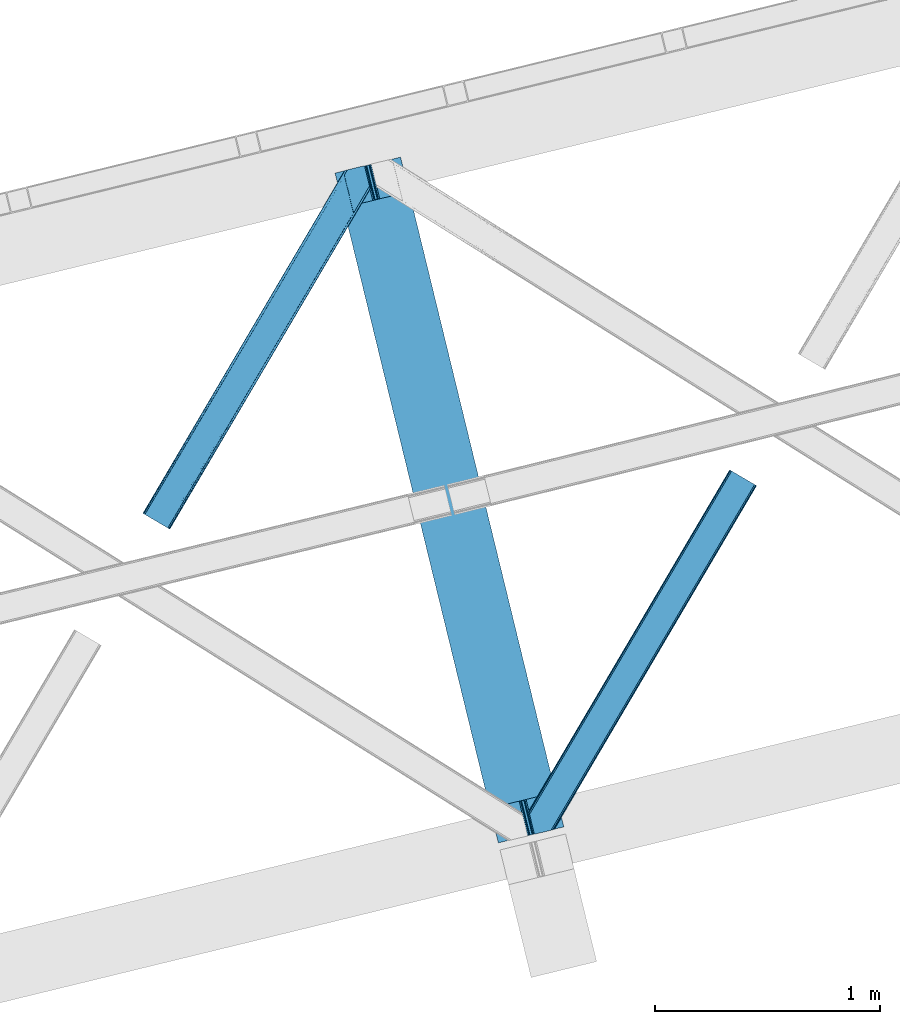
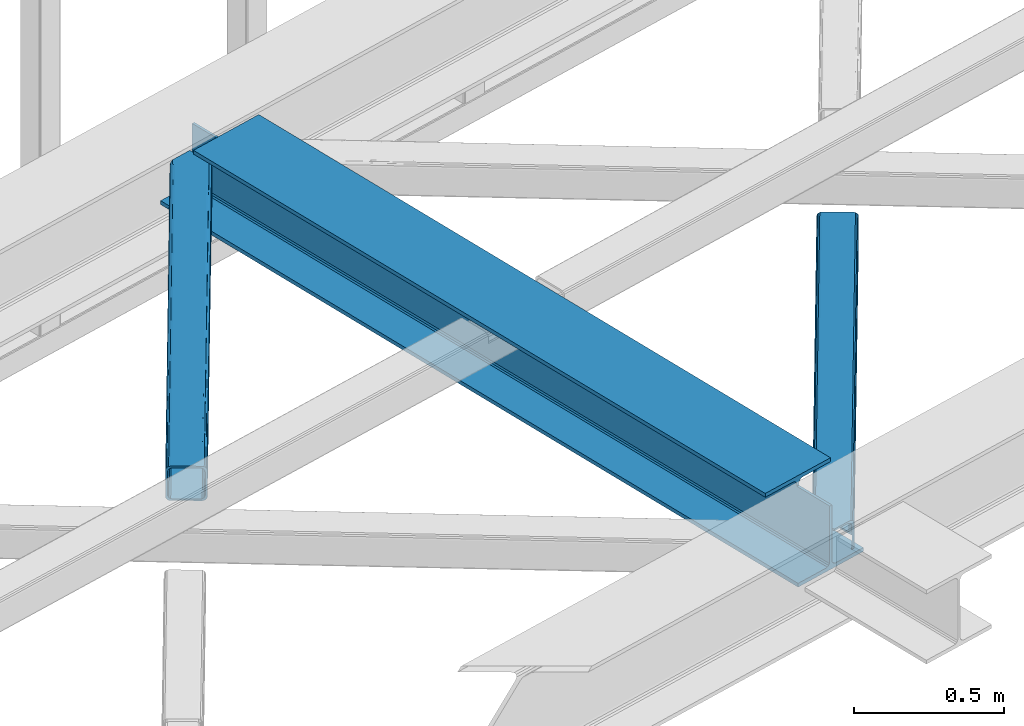
# One storey, part 21 of 67: 2 members, 1 beam.
"""IFC4 building model written with IfcOpenShell, lengths in millimetres."""

from ifc_helpers import new_model, entity, si_unit, converted_unit, derived_unit, direction, frame, origin, place, context, subcontext, project, spatial, triangles, polygons, material, type_object, element, save


model = new_model("IFC4")

# Units and contexts
model_context = context("Model", 3, precision=0.01, world=origin(), true_north=direction((6.12303176911189e-17, 1.0)))
plan_context = context("Plan", 3, precision=0.01, world=origin(), true_north=direction((6.12303176911189e-17, 1.0)))
body_context = subcontext(model_context, "Body", "Model", "MODEL_VIEW")
ifc_project = project(units=[si_unit("LENGTHUNIT", "METRE", prefix="MILLI"), si_unit("AREAUNIT", "SQUARE_METRE"), si_unit("VOLUMEUNIT", "CUBIC_METRE"), converted_unit("PLANEANGLEUNIT", "DEGREE", entity("IfcRatioMeasure", 0.0174532925199433), si_unit("PLANEANGLEUNIT", "RADIAN"), dimensions=[0, 0, 0, 0, 0, 0, 0]), si_unit("MASSUNIT", "GRAM", prefix="KILO"), derived_unit("MASSDENSITYUNIT", [(si_unit("MASSUNIT", "GRAM", prefix="KILO"), 1), (si_unit("LENGTHUNIT", "METRE"), -3)]), derived_unit("MOMENTOFINERTIAUNIT", [(si_unit("LENGTHUNIT", "METRE"), 4)]), si_unit("TIMEUNIT", "SECOND"), si_unit("FREQUENCYUNIT", "HERTZ"), si_unit("THERMODYNAMICTEMPERATUREUNIT", "DEGREE_CELSIUS"), derived_unit("THERMALTRANSMITTANCEUNIT", [(si_unit("MASSUNIT", "GRAM", prefix="KILO"), 1), (si_unit("THERMODYNAMICTEMPERATUREUNIT", "KELVIN"), -1), (si_unit("TIMEUNIT", "SECOND"), -3)]), derived_unit("VOLUMETRICFLOWRATEUNIT", [(si_unit("LENGTHUNIT", "METRE"), 3), (si_unit("TIMEUNIT", "SECOND"), -1)]), derived_unit("MASSFLOWRATEUNIT", [(si_unit("MASSUNIT", "GRAM", prefix="KILO"), 1), (si_unit("TIMEUNIT", "SECOND"), -1)]), derived_unit("ROTATIONALFREQUENCYUNIT", [(si_unit("TIMEUNIT", "SECOND"), -1)]), si_unit("ELECTRICCURRENTUNIT", "AMPERE"), si_unit("ELECTRICVOLTAGEUNIT", "VOLT"), si_unit("POWERUNIT", "WATT"), si_unit("FORCEUNIT", "NEWTON", prefix="KILO"), si_unit("ILLUMINANCEUNIT", "LUX"), si_unit("LUMINOUSFLUXUNIT", "LUMEN"), si_unit("LUMINOUSINTENSITYUNIT", "CANDELA"), derived_unit("USERDEFINED", [(si_unit("MASSUNIT", "GRAM", prefix="KILO"), -1), (si_unit("LENGTHUNIT", "METRE"), -2), (si_unit("TIMEUNIT", "SECOND"), 3), (si_unit("LUMINOUSFLUXUNIT", "LUMEN"), 1)]), derived_unit("LINEARVELOCITYUNIT", [(si_unit("LENGTHUNIT", "METRE"), 1), (si_unit("TIMEUNIT", "SECOND"), -1)]), si_unit("PRESSUREUNIT", "PASCAL"), derived_unit("USERDEFINED", [(si_unit("LENGTHUNIT", "METRE"), -2), (si_unit("MASSUNIT", "GRAM", prefix="KILO"), 1), (si_unit("TIMEUNIT", "SECOND"), -2)]), derived_unit("LINEARFORCEUNIT", [(si_unit("MASSUNIT", "GRAM", prefix="KILO"), 1), (si_unit("LENGTHUNIT", "METRE"), 1), (si_unit("TIMEUNIT", "SECOND"), -2), (si_unit("LENGTHUNIT", "METRE"), -1)]), derived_unit("PLANARFORCEUNIT", [(si_unit("MASSUNIT", "GRAM", prefix="KILO"), 1), (si_unit("LENGTHUNIT", "METRE"), 1), (si_unit("TIMEUNIT", "SECOND"), -2), (si_unit("LENGTHUNIT", "METRE"), -2)])], contexts=[model_context, plan_context])

# Site, building, storey
site_placement = place(None, origin())
site = spatial("IfcSite", under=ifc_project, at=site_placement, CompositionType="ELEMENT")
building_placement = place(site_placement, origin())
building = spatial("IfcBuilding", under=site, at=building_placement, CompositionType="ELEMENT")
storey_placement = place(building_placement, frame((0.0, 0.0, 19800.0)))
storey = spatial("IfcBuildingStorey", under=building, at=storey_placement, CompositionType="ELEMENT", Elevation=19800.0)

# Beam
ifc_material = material(Name="Metal painted (White)")
beam_type = type_object("IfcBeamType", PredefinedType="BEAM")
beam_placement = place(storey_placement, frame((-55322.2583208629, 4310.45727216739, 3808.0)))
element("IfcBeam", 1, at=beam_placement, inside=storey, type_object=beam_type, material=ifc_material, ObjectType="Steel Beam", PredefinedType="BEAM", context=body_context, shape_type="Tessellation", body=[
    polygons([(1017.69283159732, 71.0478278971021, 15.5000000000051), (1017.69283159732, 71.0478278971021, 0.0), (291.465617442455, 3050.31221418793, 0.0), (291.465617442455, 3050.31221418793, 15.5000000000051), (894.305720213346, 40.9709140873291, 15.5000000000051), (168.078506058482, 3020.23530037816, 15.5000000000051), (887.613376439383, 39.3395844888243, 16.8701684148028), (161.386162284528, 3018.60397077965, 16.8701684148028), (881.939881338776, 37.9566100336519, 20.7720779386478), (155.712667183904, 3017.22099632448, 20.7720779386478), (878.148973110201, 37.0325360459184, 26.6116982174338), (151.921758955329, 3016.29692233675, 26.6116982174338), (876.817783166804, 36.7080444135029, 33.500000000001), (150.590569011932, 3015.97243070433, 33.500000000001), (140.875048430522, 3013.60416977443, 33.500000000001), (140.875048430522, 3013.60416977443, 259.000000000006), (150.590569011932, 3015.97243070433, 259.000000000006), (0.0, 2979.26438629083, 4.33146851719357e-12), (0.0, 2979.26438629083, 15.5000000000051), (123.387111383964, 3009.3413001006, 15.5000000000051), (130.079455157926, 3010.97262969911, 16.8701684148028), (135.752950258551, 3012.35560415428, 20.7720779386478), (139.543858487126, 3013.27967814201, 26.6116982174338), (876.817783166804, 36.7080444135029, 259.000000000006), (867.102262585394, 34.3397834835998, 259.000000000006), (867.102262585394, 34.3397834835998, 33.500000000001), (865.771072641989, 34.0152918511854, 26.6116982174338), (861.980164413414, 33.0912178634502, 20.7720779386478), (856.306669312798, 31.7082434082778, 16.8701684148028), (849.614325538844, 30.0769138097735, 15.5000000000051), (726.227214154872, 5.41433564649196e-13, 15.5000000000051), (726.22721415488, 0.0, 4.33146851719357e-12), (839.486273629598, 189.856409617334, 259.069792697269), (187.831472134673, 2863.19586956159, 259.000000000006), (188.054865236505, 2862.27942515662, 259.617303331129), (188.06725408013, 2862.22860092284, 266.500003008253), (839.341094842841, 190.451887551109, 266.500002998871), (839.341444963593, 190.450451246374, 260.000004007593), (829.861336398987, 187.116337424106, 259.006343170226), (829.637966360804, 188.032789031317, 259.617303331129), (829.625577517179, 188.08361326509, 266.500003008253), (178.351736754486, 2859.86032663682, 266.500002998871), (178.351386633734, 2859.86176294156, 260.000004007593), (178.20658097539, 2860.45581175535, 259.076120467494), (178.115951553254, 2860.82760863168, 259.000000000006), (840.672582712759, 190.775156995794, 273.388305639792), (844.462859301464, 191.701822167707, 279.227924098781), (850.135930248994, 193.086536631384, 283.129832400619), (856.828121930127, 194.718490162197, 284.500000377228), (980.21515061798, 224.795743217309, 284.500000138975), (980.213480811311, 224.802593286041, 299.999995328161), (688.748058714041, 153.753964021999, 299.999995890966), (688.749728520692, 153.747113953267, 284.500000701776), (812.136757208545, 183.824367008377, 284.500000463524), (818.829244104684, 185.455109474956, 283.129832461069), (824.503155753444, 186.836375119481, 279.227924137327), (828.294690540436, 187.757878768779, 273.388305663689), (177.020248884559, 2859.53705719214, 273.388305639792), (173.229972295863, 2858.61039202022, 279.227924098781), (167.556901348333, 2857.22567755655, 283.129832400619), (160.864709667199, 2855.59372402573, 284.500000377228), (37.4776809793468, 2825.51647097062, 284.500000138975), (37.4793507860071, 2825.50962090189, 299.999995328161), (328.944772883286, 2896.55825016593, 299.999995890962), (328.943103076634, 2896.56510023467, 284.500000701776), (205.556074388782, 2866.48784717955, 284.500000463524), (198.863587492643, 2864.85710471298, 283.129832461069), (193.189675843874, 2863.47583906845, 279.227924137327), (189.398141056891, 2862.55433541915, 273.388305663689)], [[[1, 2, 3, 4]], [[5, 1, 4, 6]], [[7, 5, 6, 8]], [[9, 7, 8, 10]], [[11, 9, 10, 12]], [[13, 11, 12, 14]], [[15, 16, 17, 14, 12, 10, 8, 6, 4, 3, 18, 19, 20, 21, 22, 23]], [[13, 24, 25, 26, 27, 28, 29, 30, 31, 32, 2, 1, 5, 7, 9, 11]], [[2, 32, 18, 3]], [[32, 31, 19, 18]], [[31, 30, 20, 19]], [[27, 26, 15, 23]], [[28, 27, 23, 22]], [[29, 28, 22, 21]], [[30, 29, 21, 20]], [[33, 24, 13, 14, 17, 34, 35, 36, 37, 38]], [[25, 39, 40, 41, 42, 43, 44, 16, 15, 26]], [[39, 25, 24, 33]], [[45, 34, 17, 16]], [[41, 40, 38, 37, 46, 47, 48, 49, 50, 51, 52, 53, 54, 55, 56, 57]], [[42, 58, 59, 60, 61, 62, 63, 64, 65, 66, 67, 68, 69, 36, 35, 43]], [[46, 37, 36, 69]], [[47, 46, 69, 68]], [[48, 47, 68, 67]], [[49, 48, 67, 66]], [[50, 49, 66, 65]], [[51, 50, 65, 64]], [[52, 51, 64, 63]], [[53, 52, 63, 62]], [[54, 53, 62, 61]], [[55, 54, 61, 60]], [[56, 55, 60, 59]], [[57, 56, 59, 58]], [[41, 57, 58, 42]]], closed=False),
])

# Members
member_type_1 = type_object("IfcMemberType", PredefinedType="BRACE")
member_1_placement = place(storey_placement, frame((-56177.5849365234, 5705.46744232178, 3823.99987792968)))
element("IfcMember", 2, at=member_1_placement, inside=storey, type_object=member_type_1, ObjectType="Steel Horizontal Brace", PredefinedType="BRACE", context=body_context, shape_type="Tessellation", body=[
    triangles([(105.560998535155, 8.87794647216833, 0.0), (15.078149414061, 62.148532104492, 0.0), (892.843176269533, 1346.13992614746, 0.0), (857.166284179686, 1492.50250396729, 0.0), (854.892004394533, 1501.83739929199, 1.33247680664135), (9.30640869140916, 65.5459991455082, 1.33247680664135), (852.961889648439, 1509.75145111084, 5.12526855468968), (4.41368408202834, 68.4266372680668, 5.12526855468968), (851.673596191409, 1515.03950042725, 10.8039916992202), (1.14411621094041, 70.3509384155277, 10.8039916992202), (851.222460937497, 1516.89636383057, 17.5012573242202), (0.0, 71.0270599365231, 17.5012573242202), (893.633825683595, 1342.89768218994, 0.155804443358647), (111.332739257814, 5.48047943115216, 1.33247680664135), (899.559045410155, 1344.34178009033, 1.33247680664135), (912.390820312503, 1347.46949615478, 10.8039916992202), (914.195361328122, 1347.90958557129, 17.5012573242202), (120.643798828125, 0.0, 17.5012573242202), (119.495031738283, 0.675540161132631, 10.8039916992202), (907.251599121097, 1346.21666564941, 5.12526855468968), (116.225463867188, 2.60042266845721, 5.12526855468968), (902.493750000001, 1345.05743408203, 17.9802978515618), (893.633825683595, 1342.89768218994, 9.69243164062573), (897.763806152347, 1343.90459747314, 12.1248413085959), (903.721582031249, 1345.35683441162, 19.5011352539077), (914.195361328122, 1347.90958557129, 19.5011352539077), (1011.61732177735, 1513.38669433594, 19.5011352539077), (1008.98957519532, 1524.16103668213, 19.5011352539077), (1011.61732177735, 1513.38669433594, 122.499499511719), (120.643798828125, 0.0, 122.499499511719), (114.61160888672, 3.55094604492206, 24.5008300781265), (1009.23607177734, 1523.14423828125, 24.5008300781265), (113.462841796878, 4.22706756591833, 17.8035644531265), (110.193273925783, 6.15136871337927, 12.1248413085959), (105.300549316409, 9.03200683593786, 8.3320495605476), (99.52880859375, 12.4294738769531, 6.99957275390625), (892.685046386716, 1346.79976959229, 8.8831787109375), (890.466577148436, 1355.89747009277, 6.99957275390625), (21.1103393554658, 58.5970046997072, 6.99957275390625), (859.547534179685, 1482.74496002197, 6.99957275390625), (853.961828613283, 1505.66042175293, 18.501196289064), (851.222460937497, 1516.89636383057, 18.501196289064), (854.092053222659, 1505.10871124268, 17.8803039550803), (855.338488769528, 1499.99390716553, 12.1248413085959), (857.268603515622, 1492.07985534668, 8.3320495605476), (1009.23607177734, 1523.14423828125, 115.499926757813), (114.61160888672, 3.55094604492206, 115.499926757813), (1008.78493652344, 1525.00110168457, 122.197192382813), (113.462841796878, 4.22706756591833, 122.197192382813), (1007.49664306641, 1530.28856964111, 127.873590087893), (110.193273925783, 6.15136871337927, 127.873590087893), (1005.56652832031, 1538.20262145996, 131.668707275392), (105.300549316409, 9.03200683593786, 131.668707275392), (1003.29224853516, 1547.53809814453, 133.001184082033), (99.52880859375, 12.4294738769531, 133.001184082033), (851.947998046875, 1518.13291625977, 19.5011352539077), (854.575744628906, 1507.35857391357, 19.5011352539077), (851.775915527345, 1517.83991088867, 19.2639404296897), (854.426916503908, 1506.95045928955, 19.2592895507805), (851.585229492186, 1517.51434936523, 19.0011657714858), (854.268786621091, 1506.50920715332, 19.0011657714858), (851.394543457034, 1517.1887878418, 18.7360656738274), (854.106005859372, 1506.06795501709, 18.7407165527366), (908.014343261719, 1598.12628936768, 19.5011352539077), (897.540563964845, 1595.57353820801, 19.5011352539077), (1011.16153564453, 1515.24355773926, 129.196765136719), (1009.8732421875, 1520.53160705566, 134.87548828125), (1008.43146972657, 1526.45624542236, 138.000878906252), (986.307238769528, 1617.21117095947, 138.000878906252), (986.307238769528, 1617.21117095947, 133.001184082033), (897.540563964845, 1595.57353820801, 122.499499511719), (0.0, 71.0270599365231, 122.499499511719), (7.17630615234521, 66.799411010742, 17.8035644531265), (10.4458740234404, 64.8751098632811, 12.1248413085959), (6.03218994140479, 67.4755325317383, 24.5008300781265), (907.023706054686, 1597.88560638428, 24.5008300781265), (15.338598632814, 61.9944717407225, 8.3320495605476), (908.828247070313, 1598.32511444092, 122.197192382813), (899.345104980472, 1596.01362762451, 129.196765136719), (904.484326171878, 1597.26645812988, 134.87548828125), (930.73388671875, 1603.66490478516, 133.001184082033), (910.24211425781, 1598.66986083984, 138.000878906252), (921.660021972653, 1601.45341186523, 131.668707275392), (913.967468261719, 1599.57852630615, 127.873590087893), (907.023706054686, 1597.88560638428, 115.499926757813), (21.1103393554658, 58.5970046997072, 133.001184082033), (6.03218994140479, 67.4755325317383, 115.499926757813), (15.338598632814, 61.9944717407225, 131.668707275392), (10.4458740234404, 64.8751098632811, 127.873590087893), (7.17630615234521, 66.799411010742, 122.197192382813), (119.495031738283, 0.675540161132631, 129.196765136719), (116.225463867188, 2.60042266845721, 134.87548828125), (111.332739257814, 5.48047943115216, 138.668280029298), (105.560998535155, 8.87794647216833, 140.00075683594), (15.078149414061, 62.148532104492, 140.00075683594), (9.30640869140916, 65.5459991455082, 138.668280029298), (4.41368408202834, 68.4266372680668, 134.87548828125), (1.14411621094041, 70.3509384155277, 129.196765136719), (896.987109374997, 1576.15553741455, 138.000878906252), (938.18924560547, 1407.14434204102, 138.000878906252), (899.019543457034, 1563.59525756836, 140.00075683594), (897.038269042969, 1571.72266845703, 139.000817871096), (896.796423339845, 1573.13653564453, 138.638049316407), (896.926647949222, 1575.15443572998, 138.212493896484), (896.86153564453, 1574.14112548828, 138.426434326171), (937.473010253903, 1407.08562469482, 138.293884277344), (937.077685546872, 1408.09486541748, 138.647351074218), (936.682360839841, 1409.10410614014, 139.000817871096), (934.701086425783, 1417.23267974853, 140.00075683594)], [[1, 2, 3], [4, 3, 2], [5, 4, 6], [2, 6, 4], [7, 5, 8], [6, 8, 5], [9, 7, 10], [8, 10, 7], [11, 9, 12], [10, 12, 9], [1, 3, 13], [13, 14, 1], [13, 15, 14], [16, 17, 18], [18, 19, 16], [20, 16, 19], [19, 21, 20], [15, 20, 21], [21, 14, 15], [20, 22, 16], [23, 24, 15], [23, 15, 13], [15, 24, 20], [16, 25, 17], [20, 24, 22], [16, 22, 25], [26, 17, 25], [26, 25, 27], [28, 27, 25], [27, 29, 26], [30, 26, 29], [26, 18, 17], [30, 18, 26], [31, 32, 25], [25, 33, 31], [25, 22, 33], [32, 28, 25], [33, 22, 24], [34, 24, 23], [23, 35, 34], [36, 35, 37], [37, 38, 36], [23, 37, 35], [24, 34, 33], [39, 36, 38], [38, 40, 39], [9, 11, 41], [11, 42, 41], [43, 9, 41], [43, 7, 9], [44, 7, 43], [5, 44, 45], [44, 5, 7], [4, 5, 45], [45, 40, 4], [37, 23, 13], [37, 3, 38], [3, 40, 38], [40, 3, 4], [37, 13, 3], [46, 32, 31], [31, 47, 46], [48, 46, 49], [47, 49, 46], [50, 48, 51], [49, 51, 48], [52, 50, 53], [51, 53, 50], [54, 52, 55], [53, 55, 52], [56, 57, 58], [59, 58, 57], [58, 59, 60], [61, 60, 59], [60, 61, 62], [63, 62, 61], [62, 63, 42], [41, 42, 63], [57, 56, 64], [65, 64, 56], [66, 48, 67], [46, 29, 27], [27, 32, 46], [32, 27, 28], [48, 29, 46], [66, 29, 48], [50, 68, 67], [52, 68, 50], [67, 48, 50], [52, 54, 68], [54, 69, 68], [70, 69, 54], [71, 60, 62], [58, 60, 71], [71, 56, 58], [56, 71, 65], [42, 12, 72], [12, 42, 11], [71, 42, 72], [42, 71, 62], [73, 74, 44], [75, 73, 43], [43, 41, 75], [43, 57, 75], [64, 76, 57], [75, 57, 76], [44, 43, 73], [45, 44, 74], [74, 77, 45], [40, 45, 77], [77, 39, 40], [78, 79, 80], [81, 82, 69], [69, 70, 81], [81, 83, 82], [84, 82, 83], [80, 82, 84], [78, 71, 79], [85, 71, 78], [80, 84, 78], [65, 76, 64], [85, 65, 71], [76, 65, 85], [86, 54, 55], [54, 86, 81], [70, 54, 81], [76, 85, 87], [87, 75, 76], [83, 81, 86], [86, 88, 83], [84, 83, 88], [88, 89, 84], [78, 84, 89], [89, 90, 78], [85, 78, 90], [90, 87, 85], [91, 51, 49], [47, 18, 30], [91, 49, 30], [91, 92, 51], [49, 47, 30], [51, 92, 93], [55, 94, 95], [94, 53, 93], [53, 94, 55], [53, 51, 93], [19, 34, 21], [31, 18, 47], [18, 33, 19], [33, 18, 31], [19, 33, 34], [1, 36, 2], [14, 21, 34], [34, 35, 14], [35, 36, 1], [1, 14, 35], [89, 96, 97], [95, 86, 55], [95, 88, 86], [88, 95, 96], [89, 88, 96], [87, 72, 12], [98, 90, 89], [97, 98, 89], [90, 98, 72], [87, 90, 72], [6, 74, 8], [2, 36, 39], [39, 77, 2], [77, 74, 6], [6, 2, 77], [10, 8, 74], [12, 75, 87], [73, 12, 10], [12, 73, 75], [73, 10, 74], [99, 68, 82], [99, 100, 68], [68, 69, 82], [96, 95, 101], [101, 102, 96], [97, 96, 103], [104, 97, 105], [104, 99, 97], [97, 103, 105], [82, 80, 99], [97, 99, 80], [102, 103, 96], [79, 71, 98], [72, 98, 71], [80, 79, 97], [98, 97, 79], [92, 67, 100], [100, 93, 92], [67, 68, 100], [106, 107, 93], [94, 93, 107], [107, 108, 94], [108, 109, 94], [66, 67, 92], [92, 91, 66], [29, 66, 91], [91, 30, 29], [95, 94, 109], [109, 101, 95], [107, 103, 102], [105, 103, 107], [106, 104, 105], [100, 99, 104], [107, 106, 105], [102, 108, 107], [102, 101, 109], [109, 108, 102]]),
])
member_type_2 = type_object("IfcMemberType", PredefinedType="BRACE")
member_2_placement = place(storey_placement, frame((-54460.7408935547, 4348.57584686279, 3823.99987792968)))
element("IfcMember", 3, at=member_2_placement, inside=storey, type_object=member_type_2, ObjectType="Steel Horizontal Brace", PredefinedType="BRACE", context=body_context, shape_type="Tessellation", body=[
    triangles([(154.451037597661, 124.708957672119, 0.0), (118.774145507814, 271.071535491944, 0.0), (998.971582031256, 1559.19901428223, 0.0), (908.488732910162, 1612.46901855469, 0.0), (1004.74332275391, 1555.80096588135, 1.33247680664135), (156.725317382814, 115.37377166748, 1.33247680664135), (1009.63604736328, 1552.92090911865, 5.12526855468968), (158.655432128908, 107.459719848634, 5.12526855468968), (1012.90561523438, 1550.99602661133, 10.8039916992202), (159.943725585938, 102.171961212159, 10.8039916992202), (1014.05438232422, 1550.3204864502, 17.5012573242202), (160.39486083985, 100.315097808838, 17.5012573242202), (902.716992187503, 1615.8664855957, 1.33247680664135), (116.495214843751, 280.406721496583, 1.33247680664135), (114.579052734378, 288.275717926026, 5.1694519042976), (897.824267578129, 1618.74712371826, 5.12526855468968), (114.499987792973, 288.596628570557, 5.32758178711083), (894.554699707034, 1620.67142486572, 10.8039916992202), (109.630517578131, 287.409491729737, 10.8039916992202), (893.410583496094, 1621.34754638672, 17.5012573242202), (107.825976562504, 286.969402313232, 17.5012573242202), (113.527954101563, 288.360015106202, 18.5197998046897), (114.499987792973, 288.596628570557, 17.5198608398459), (114.42557373047, 288.578606414795, 17.9035583496116), (114.216284179689, 288.527446746826, 18.2267944335945), (113.900024414063, 288.450416564941, 18.4453857421868), (107.825976562504, 286.969402313232, 18.5197998046897), (115.695263671878, 283.683847045899, 17.5198608398459), (115.625500488284, 283.800700378419, 17.8035644531265), (115.569689941411, 283.740529632569, 17.8570495605491), (115.323193359378, 283.495777130127, 18.0779663085959), (115.067395019534, 283.23939743042, 18.3081848144539), (114.834851074222, 283.003365325928, 18.5197998046897), (0.0, 103.824767303468, 18.5197998046897), (2.73936767578562, 92.5989990234375, 18.5197998046897), (893.410583496094, 1621.34754638672, 122.499499511719), (0.0, 103.824767303468, 122.499499511719), (908.488732910162, 1612.46901855469, 140.00075683594), (902.716992187503, 1615.8664855957, 138.668280029298), (3.6741943359375, 88.7660934448249, 138.668280029298), (5.94847412109812, 79.4309074401863, 140.00075683594), (897.824267578129, 1618.74712371826, 134.87548828125), (1.74407958984375, 96.6801452636719, 134.87548828125), (894.554699707034, 1620.67142486572, 129.196765136719), (0.455786132813955, 101.967903900147, 129.196765136719), (899.442773437506, 1617.79601898193, 24.5008300781265), (2.38125000000582, 94.0672233581545, 24.5008300781265), (900.591540527348, 1617.1204788208, 17.8035644531265), (903.856457519534, 1615.19559631348, 12.1248413085959), (914.520922851567, 1608.9174911499, 6.99957275390625), (908.749182128908, 1612.31553955078, 8.3320495605476), (118.87646484375, 270.64917755127, 8.3320495605476), (121.150744628911, 261.313991546631, 6.99957275390625), (116.946350097656, 278.563229370117, 12.1248413085959), (152.069787597662, 134.466501617432, 6.99957275390625), (992.939392089844, 1562.74996032715, 6.99957275390625), (156.274182128909, 117.217263793946, 12.1248413085959), (154.344067382815, 125.131315612794, 8.3320495605476), (157.525268554688, 112.096936798096, 17.5198608398459), (160.39486083985, 100.315097808838, 17.5198608398459), (899.442773437506, 1617.79601898193, 115.499926757813), (2.38125000000582, 94.0672233581545, 115.499926757813), (900.591540527348, 1617.1204788208, 122.197192382813), (2.83238525391062, 92.2103599548345, 122.197192382813), (903.856457519534, 1615.19559631348, 127.873590087893), (4.12067871094041, 86.9226013183597, 127.873590087893), (908.749182128908, 1612.31553955078, 131.668707275392), (6.05079345703416, 79.0085494995119, 131.668707275392), (914.520922851567, 1608.9174911499, 133.001184082033), (8.3250732421875, 69.6736541748051, 133.001184082033), (25.3100830078183, 0.0, 133.001184082033), (25.3100830078183, 0.0, 140.00075683594), (90.3665771484375, 15.8583343505861, 140.00075683594), (998.971582031256, 1559.19901428223, 140.00075683594), (1014.05438232422, 1550.3204864502, 122.499499511719), (1012.90561523438, 1550.99602661133, 129.196765136719), (114.076757812501, 21.6379234313972, 122.499499511719), (112.272216796875, 21.1978340148926, 129.196765136719), (1009.63604736328, 1552.92090911865, 134.87548828125), (107.132995605469, 19.9450035095215, 134.87548828125), (1004.74332275391, 1555.80096588135, 138.668280029298), (99.4404418945342, 18.0698272705085, 138.668280029298), (159.669323730472, 99.0785453796389, 18.5197998046897), (114.076757812501, 21.6379234313972, 18.5197998046897), (103.165795898443, 18.9782020568855, 18.5197998046897), (156.929956054693, 110.3046043396, 18.5197998046897), (1008.02219238281, 1553.87201385498, 24.5008300781265), (1006.87342529297, 1554.54755401611, 17.8035644531265), (157.22761230469, 111.200770568848, 18.0198303222678), (1003.60385742188, 1556.47243652344, 12.1248413085959), (998.711132812503, 1559.35249328613, 8.3320495605476), (104.593615722661, 19.3261459350588, 24.5008300781265), (1003.60385742188, 1556.47243652344, 127.873590087893), (1008.02219238281, 1553.87201385498, 115.499926757813), (1006.87342529297, 1554.54755401611, 122.197192382813), (992.939392089844, 1562.74996032715, 133.001184082033), (998.711132812503, 1559.35249328613, 131.668707275392), (102.789074707034, 18.8860565185551, 122.197192382813), (80.8834350585967, 13.5465568542486, 133.001184082033), (89.9572998046933, 15.7580497741701, 131.668707275392), (97.6498535156279, 17.633226013184, 127.873590087893), (104.593615722661, 19.3261459350588, 115.499926757813)], [[1, 2, 3], [4, 3, 2], [3, 5, 1], [6, 1, 5], [5, 7, 6], [8, 6, 7], [7, 9, 8], [10, 8, 9], [9, 11, 10], [12, 10, 11], [13, 14, 15], [16, 15, 17], [17, 18, 16], [17, 19, 18], [20, 18, 19], [19, 21, 20], [15, 16, 13], [13, 4, 14], [2, 14, 4], [22, 23, 24], [22, 25, 26], [27, 21, 22], [24, 25, 22], [23, 22, 21], [21, 19, 23], [17, 23, 19], [23, 28, 29], [29, 24, 23], [25, 24, 30], [26, 25, 31], [22, 26, 32], [32, 33, 22], [31, 32, 26], [30, 31, 25], [29, 30, 24], [34, 33, 35], [33, 34, 27], [22, 33, 27], [27, 20, 21], [36, 27, 37], [27, 36, 20], [27, 34, 37], [38, 39, 40], [40, 41, 38], [39, 42, 43], [43, 40, 39], [42, 44, 45], [45, 43, 42], [44, 36, 37], [37, 45, 44], [46, 47, 33], [33, 48, 46], [33, 31, 48], [47, 35, 33], [49, 48, 28], [50, 51, 52], [52, 53, 50], [51, 49, 54], [54, 52, 51], [28, 54, 49], [53, 55, 56], [56, 50, 53], [55, 2, 1], [54, 17, 14], [52, 14, 2], [52, 2, 53], [55, 53, 2], [17, 28, 23], [54, 28, 17], [52, 54, 14], [57, 58, 6], [58, 1, 6], [1, 58, 55], [8, 57, 6], [8, 59, 57], [10, 59, 8], [10, 60, 59], [46, 61, 47], [62, 47, 61], [61, 63, 62], [64, 62, 63], [63, 65, 64], [66, 64, 65], [65, 67, 66], [68, 66, 67], [67, 69, 68], [70, 68, 69], [66, 43, 64], [71, 72, 70], [72, 41, 70], [40, 68, 41], [66, 68, 40], [68, 70, 41], [66, 40, 43], [37, 34, 62], [45, 64, 43], [62, 64, 37], [64, 45, 37], [34, 47, 62], [34, 35, 47], [41, 73, 74], [73, 41, 72], [74, 38, 41], [75, 76, 77], [78, 77, 76], [76, 79, 78], [80, 78, 79], [79, 81, 80], [82, 80, 81], [81, 74, 82], [73, 82, 74], [60, 75, 77], [60, 11, 75], [77, 83, 60], [77, 84, 83], [84, 85, 83], [86, 83, 85], [87, 88, 59], [89, 86, 87], [88, 90, 57], [57, 59, 88], [90, 91, 58], [58, 57, 90], [91, 56, 55], [55, 58, 91], [87, 86, 92], [85, 92, 86], [9, 90, 88], [87, 75, 11], [9, 88, 11], [9, 7, 90], [88, 87, 11], [90, 7, 5], [56, 3, 4], [3, 91, 5], [91, 3, 56], [91, 90, 5], [76, 93, 79], [94, 75, 87], [75, 95, 76], [95, 75, 94], [76, 95, 93], [74, 96, 38], [81, 79, 93], [93, 97, 81], [97, 96, 74], [74, 81, 97], [49, 13, 16], [4, 50, 56], [4, 51, 50], [51, 4, 13], [49, 51, 13], [46, 20, 36], [18, 48, 49], [16, 18, 49], [48, 18, 20], [46, 48, 20], [39, 65, 42], [38, 96, 69], [69, 67, 38], [67, 65, 39], [39, 38, 67], [44, 42, 65], [36, 61, 46], [63, 36, 44], [36, 63, 61], [63, 44, 65], [98, 78, 80], [99, 73, 72], [72, 71, 99], [99, 100, 73], [100, 82, 73], [101, 82, 100], [80, 82, 101], [98, 77, 78], [102, 77, 98], [80, 101, 98], [84, 92, 85], [102, 84, 77], [92, 84, 102], [99, 70, 96], [99, 71, 70], [69, 96, 70], [96, 97, 100], [100, 99, 96], [97, 93, 101], [101, 100, 97], [93, 95, 98], [98, 101, 93], [95, 94, 102], [102, 98, 95], [94, 87, 102], [92, 102, 87]]),
])

save(model, "model.ifc")
